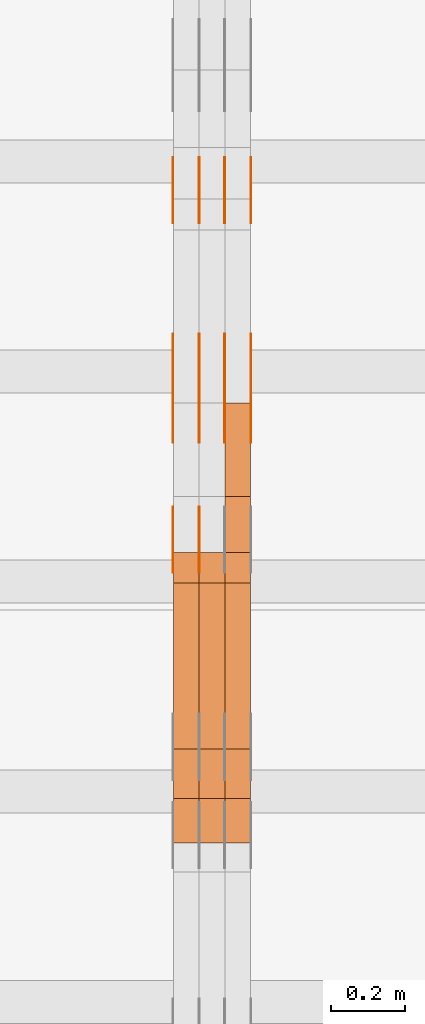
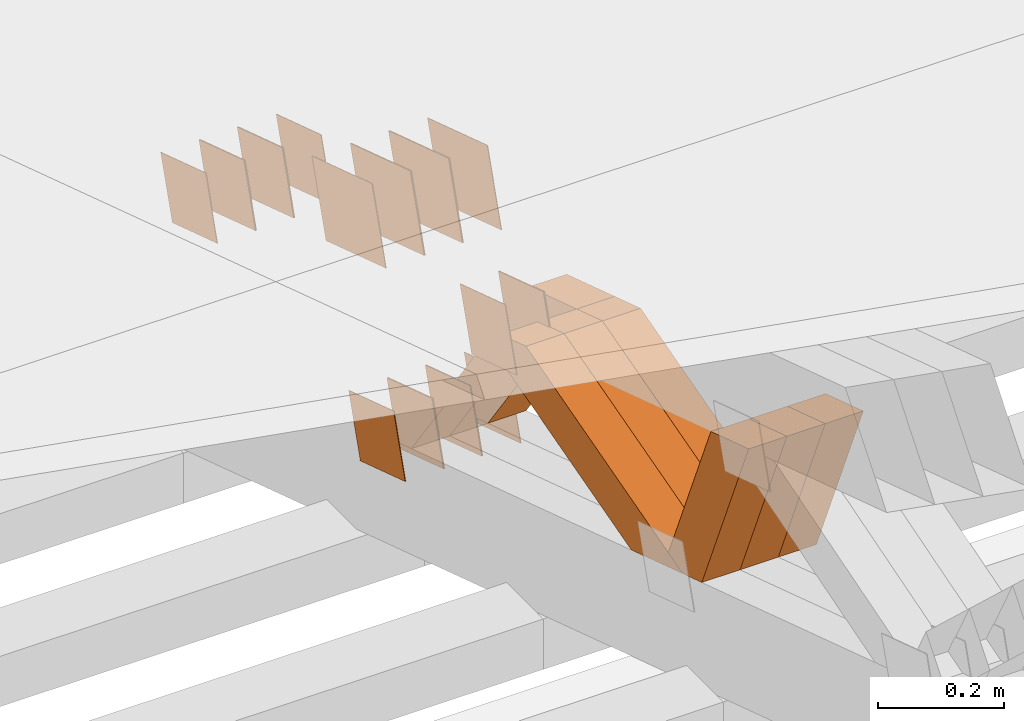
# One storey, part 206 of 385: 28 proxies.
"""IFC2X3 building model written with IfcOpenShell, lengths in millimetres."""

from ifc_helpers import new_model, entity, si_unit, converted_unit, derived_unit, direction, frame, origin, place, context, subcontext, project, spatial, polyline, outline, extrude, source, transform, mapped, material, type_object, type_shapes, element, save


model = new_model("IFC2X3")

# Units and contexts
model_context = context("Model", 3, precision=0.01, world=origin(), true_north=direction((6.12303176911189e-17, 1.0)))
body_context = subcontext(model_context, "Body", "Model", "MODEL_VIEW")
ifc_project = project(units=[si_unit("LENGTHUNIT", "METRE", prefix="MILLI"), si_unit("AREAUNIT", "SQUARE_METRE"), si_unit("VOLUMEUNIT", "CUBIC_METRE"), converted_unit("PLANEANGLEUNIT", "DEGREE", entity("IfcRatioMeasure", 0.0174532925199433), si_unit("PLANEANGLEUNIT", "RADIAN"), dimensions=[0, 0, 0, 0, 0, 0, 0]), si_unit("MASSUNIT", "GRAM", prefix="KILO"), derived_unit("MASSDENSITYUNIT", [(si_unit("MASSUNIT", "GRAM", prefix="KILO"), 1), (si_unit("LENGTHUNIT", "METRE"), -3)]), si_unit("TIMEUNIT", "SECOND"), si_unit("FREQUENCYUNIT", "HERTZ"), si_unit("THERMODYNAMICTEMPERATUREUNIT", "DEGREE_CELSIUS"), derived_unit("THERMALTRANSMITTANCEUNIT", [(si_unit("MASSUNIT", "GRAM", prefix="KILO"), 1), (si_unit("THERMODYNAMICTEMPERATUREUNIT", "KELVIN"), -1), (si_unit("TIMEUNIT", "SECOND"), -3)]), derived_unit("VOLUMETRICFLOWRATEUNIT", [(si_unit("LENGTHUNIT", "METRE"), 3), (si_unit("TIMEUNIT", "SECOND"), -1)]), si_unit("ELECTRICCURRENTUNIT", "AMPERE"), si_unit("ELECTRICVOLTAGEUNIT", "VOLT"), si_unit("POWERUNIT", "WATT"), si_unit("FORCEUNIT", "NEWTON", prefix="KILO"), si_unit("ILLUMINANCEUNIT", "LUX"), si_unit("LUMINOUSFLUXUNIT", "LUMEN"), si_unit("LUMINOUSINTENSITYUNIT", "CANDELA"), derived_unit("USERDEFINED", [(si_unit("MASSUNIT", "GRAM", prefix="KILO"), -1), (si_unit("LENGTHUNIT", "METRE"), -2), (si_unit("TIMEUNIT", "SECOND"), 3), (si_unit("LUMINOUSFLUXUNIT", "LUMEN"), 1)]), derived_unit("LINEARVELOCITYUNIT", [(si_unit("LENGTHUNIT", "METRE"), 1), (si_unit("TIMEUNIT", "SECOND"), -1)]), si_unit("PRESSUREUNIT", "PASCAL"), derived_unit("USERDEFINED", [(si_unit("LENGTHUNIT", "METRE"), -2), (si_unit("MASSUNIT", "GRAM", prefix="KILO"), 1), (si_unit("TIMEUNIT", "SECOND"), -2)])], contexts=[model_context])

# Site, building, storey
site_placement = place(None, origin())
site = spatial("IfcSite", under=ifc_project, at=site_placement, CompositionType="ELEMENT")
building_placement = place(site_placement, origin())
building = spatial("IfcBuilding", under=site, at=building_placement, CompositionType="ELEMENT")
storey_placement = place(building_placement, origin())
storey = spatial("IfcBuildingStorey", under=building, at=storey_placement, Name="Default", CompositionType="ELEMENT", Elevation=0.0)

# Proxies
ifc_material_1 = material(Name="IfcSurfaceStyle #195289")
building_element_proxy_type_1 = type_object("IfcBuildingElementProxyType", PredefinedType="NOTDEFINED", material=ifc_material_1)
shared_shape_1 = source(origin(), body_context, "Body", "SweptSolid", [
    extrude(outline(polyline([(-74.9999766548731, -60.0000019113547), (75.000223715922, -60.0000019113547), (74.9997444633404, 60.0000019113548), (-74.9999915243893, 60.0000019113547), (-74.9999766548731, -60.0000019113547)])), frame((75.0002237159219, 60.0000770809529, 0.0), z_axis=(0.0, 0.0, 1.0), x_axis=(-1.0, 0.0, 0.0)), (0.0, 0.0, 1.0), 1.29999999999999),
])
type_shapes(building_element_proxy_type_1, [shared_shape_1])
proxy_1_placement = place(building_placement, frame((15245.0, 23985.88473314, 1148.76266928562), z_axis=(-1.0, 0.0, 0.0), x_axis=(0.0, -0.951056516295154, 0.309016994374948)))
element("IfcBuildingElementProxy", 1, at=proxy_1_placement, inside=storey, type_object=building_element_proxy_type_1, material=ifc_material_1, context=body_context, shape_type="MappedRepresentation", body=[
    mapped(shared_shape_1, transform((0.0, 0.0, 0.0), scale=1.0)),
])
ifc_material_2 = material(Name="IfcSurfaceStyle #195232")
building_element_proxy_type_2 = type_object("IfcBuildingElementProxyType", PredefinedType="NOTDEFINED", material=ifc_material_2)
shared_shape_2 = source(origin(), body_context, "Body", "SweptSolid", [
    extrude(outline(polyline([(-74.9999766548731, -60.0000019113547), (75.000223715922, -60.0000019113547), (74.9997444633404, 60.0000019113548), (-74.9999915243893, 60.0000019113547), (-74.9999766548731, -60.0000019113547)])), frame((75.0002237159219, 60.0000770809529, 0.0), z_axis=(0.0, 0.0, 1.0), x_axis=(-1.0, 0.0, 0.0)), (0.0, 0.0, 1.0), 1.29999999999999),
])
type_shapes(building_element_proxy_type_2, [shared_shape_2])
proxy_2_placement = place(building_placement, frame((15246.3, 23985.88473314, 1148.76266928562), z_axis=(-1.0, 0.0, 0.0), x_axis=(0.0, -0.951056516295154, 0.309016994374948)))
element("IfcBuildingElementProxy", 2, at=proxy_2_placement, inside=storey, type_object=building_element_proxy_type_2, material=ifc_material_2, context=body_context, shape_type="MappedRepresentation", body=[
    mapped(shared_shape_2, transform((0.0, 0.0, 0.0), scale=1.0)),
])
ifc_material_3 = material(Name="IfcSurfaceStyle #195175")
building_element_proxy_type_3 = type_object("IfcBuildingElementProxyType", PredefinedType="NOTDEFINED", material=ifc_material_3)
shared_shape_3 = source(origin(), body_context, "Body", "SweptSolid", [
    extrude(outline(polyline([(-74.9999766548731, -60.0000019113547), (75.000223715922, -60.0000019113547), (74.9997444633404, 60.0000019113548), (-74.9999915243893, 60.0000019113547), (-74.9999766548731, -60.0000019113547)])), frame((75.0002237159219, 60.0000770809529, 0.0), z_axis=(0.0, 0.0, 1.0), x_axis=(-1.0, 0.0, 0.0)), (0.0, 0.0, 1.0), 1.29999999999999),
])
type_shapes(building_element_proxy_type_3, [shared_shape_3])
proxy_3_placement = place(building_placement, frame((15175.0, 23985.88473314, 1148.76266928562), z_axis=(-1.0, 0.0, 0.0), x_axis=(0.0, -0.951056516295154, 0.309016994374948)))
element("IfcBuildingElementProxy", 3, at=proxy_3_placement, inside=storey, type_object=building_element_proxy_type_3, material=ifc_material_3, context=body_context, shape_type="MappedRepresentation", body=[
    mapped(shared_shape_3, transform((0.0, 0.0, 0.0), scale=1.0)),
])
ifc_material_4 = material(Name="IfcSurfaceStyle #195118")
building_element_proxy_type_4 = type_object("IfcBuildingElementProxyType", PredefinedType="NOTDEFINED", material=ifc_material_4)
shared_shape_4 = source(origin(), body_context, "Body", "SweptSolid", [
    extrude(outline(polyline([(-74.9998841352385, -59.9999554917014), (74.9998707133932, -59.9999554917014), (74.999874704788, 59.9999554917014), (-74.9998612829427, 59.9999554917014), (-74.9998841352385, -59.9999554917014)])), frame((75.0000802775471, 60.0000306612849, 0.0), z_axis=(0.0, 0.0, 1.0), x_axis=(-1.0, 0.0, 0.0)), (0.0, 0.0, 1.0), 1.3),
])
type_shapes(building_element_proxy_type_4, [shared_shape_4])
proxy_4_placement = place(building_placement, frame((15386.3, 24338.8869142613, 728.405515087805), z_axis=(-1.0, 0.0, 0.0), x_axis=(0.0, -0.951056516295124, 0.309016994375039)))
element("IfcBuildingElementProxy", 4, at=proxy_4_placement, inside=storey, type_object=building_element_proxy_type_4, material=ifc_material_4, context=body_context, shape_type="MappedRepresentation", body=[
    mapped(shared_shape_4, transform((0.0, 0.0, 0.0), scale=1.0)),
])
ifc_material_5 = material(Name="IfcSurfaceStyle #195061")
building_element_proxy_type_5 = type_object("IfcBuildingElementProxyType", PredefinedType="NOTDEFINED", material=ifc_material_5)
shared_shape_5 = source(origin(), body_context, "Body", "SweptSolid", [
    extrude(outline(polyline([(-74.9998841352385, -59.9999554917014), (74.9998707133932, -59.9999554917014), (74.999874704788, 59.9999554917014), (-74.9998612829427, 59.9999554917014), (-74.9998841352385, -59.9999554917014)])), frame((75.0000802775471, 60.0000306612849, 0.0), z_axis=(0.0, 0.0, 1.0), x_axis=(-1.0, 0.0, 0.0)), (0.0, 0.0, 1.0), 1.3),
])
type_shapes(building_element_proxy_type_5, [shared_shape_5])
proxy_5_placement = place(building_placement, frame((15315.0, 24338.8869142613, 728.405515087805), z_axis=(-1.0, 0.0, 0.0), x_axis=(0.0, -0.951056516295124, 0.309016994375039)))
element("IfcBuildingElementProxy", 5, at=proxy_5_placement, inside=storey, type_object=building_element_proxy_type_5, material=ifc_material_5, context=body_context, shape_type="MappedRepresentation", body=[
    mapped(shared_shape_5, transform((0.0, 0.0, 0.0), scale=1.0)),
])
ifc_material_6 = material(Name="IfcSurfaceStyle #195004")
building_element_proxy_type_6 = type_object("IfcBuildingElementProxyType", PredefinedType="NOTDEFINED", material=ifc_material_6)
shared_shape_6 = source(origin(), body_context, "Body", "SweptSolid", [
    extrude(outline(polyline([(-74.9998841352385, -59.9999554917014), (74.9998707133932, -59.9999554917014), (74.999874704788, 59.9999554917014), (-74.9998612829427, 59.9999554917014), (-74.9998841352385, -59.9999554917014)])), frame((75.0000802775471, 60.0000306612849, 0.0), z_axis=(0.0, 0.0, 1.0), x_axis=(-1.0, 0.0, 0.0)), (0.0, 0.0, 1.0), 1.3),
])
type_shapes(building_element_proxy_type_6, [shared_shape_6])
proxy_6_placement = place(building_placement, frame((15316.3, 24338.8869142613, 728.405515087805), z_axis=(-1.0, 0.0, 0.0), x_axis=(0.0, -0.951056516295124, 0.309016994375039)))
element("IfcBuildingElementProxy", 6, at=proxy_6_placement, inside=storey, type_object=building_element_proxy_type_6, material=ifc_material_6, context=body_context, shape_type="MappedRepresentation", body=[
    mapped(shared_shape_6, transform((0.0, 0.0, 0.0), scale=1.0)),
])
ifc_material_7 = material(Name="IfcSurfaceStyle #194947")
building_element_proxy_type_7 = type_object("IfcBuildingElementProxyType", PredefinedType="NOTDEFINED", material=ifc_material_7)
shared_shape_7 = source(origin(), body_context, "Body", "SweptSolid", [
    extrude(outline(polyline([(-74.9998841352385, -59.9999554917014), (74.9998707133932, -59.9999554917014), (74.999874704788, 59.9999554917014), (-74.9998612829427, 59.9999554917014), (-74.9998841352385, -59.9999554917014)])), frame((75.0000802775471, 60.0000306612849, 0.0), z_axis=(0.0, 0.0, 1.0), x_axis=(-1.0, 0.0, 0.0)), (0.0, 0.0, 1.0), 1.29999999999999),
])
type_shapes(building_element_proxy_type_7, [shared_shape_7])
proxy_7_placement = place(building_placement, frame((15245.0, 24338.8869142613, 728.405515087805), z_axis=(-1.0, 0.0, 0.0), x_axis=(0.0, -0.951056516295124, 0.309016994375039)))
element("IfcBuildingElementProxy", 7, at=proxy_7_placement, inside=storey, type_object=building_element_proxy_type_7, material=ifc_material_7, context=body_context, shape_type="MappedRepresentation", body=[
    mapped(shared_shape_7, transform((0.0, 0.0, 0.0), scale=1.0)),
])
ifc_material_8 = material(Name="IfcSurfaceStyle #194890")
building_element_proxy_type_8 = type_object("IfcBuildingElementProxyType", PredefinedType="NOTDEFINED", material=ifc_material_8)
shared_shape_8 = source(origin(), body_context, "Body", "SweptSolid", [
    extrude(outline(polyline([(-74.9998841352385, -59.9999554917014), (74.9998707133932, -59.9999554917014), (74.999874704788, 59.9999554917014), (-74.9998612829427, 59.9999554917014), (-74.9998841352385, -59.9999554917014)])), frame((75.0000802775471, 60.0000306612849, 0.0), z_axis=(0.0, 0.0, 1.0), x_axis=(-1.0, 0.0, 0.0)), (0.0, 0.0, 1.0), 1.29999999999999),
])
type_shapes(building_element_proxy_type_8, [shared_shape_8])
proxy_8_placement = place(building_placement, frame((15246.3, 24338.8869142613, 728.405515087805), z_axis=(-1.0, 0.0, 0.0), x_axis=(0.0, -0.951056516295124, 0.309016994375039)))
element("IfcBuildingElementProxy", 8, at=proxy_8_placement, inside=storey, type_object=building_element_proxy_type_8, material=ifc_material_8, context=body_context, shape_type="MappedRepresentation", body=[
    mapped(shared_shape_8, transform((0.0, 0.0, 0.0), scale=1.0)),
])
ifc_material_9 = material(Name="IfcSurfaceStyle #194833")
building_element_proxy_type_9 = type_object("IfcBuildingElementProxyType", PredefinedType="NOTDEFINED", material=ifc_material_9)
shared_shape_9 = source(origin(), body_context, "Body", "SweptSolid", [
    extrude(outline(polyline([(-74.9998841352385, -59.9999554917014), (74.9998707133932, -59.9999554917014), (74.999874704788, 59.9999554917014), (-74.9998612829427, 59.9999554917014), (-74.9998841352385, -59.9999554917014)])), frame((75.0000802775471, 60.0000306612849, 0.0), z_axis=(0.0, 0.0, 1.0), x_axis=(-1.0, 0.0, 0.0)), (0.0, 0.0, 1.0), 1.29999999999999),
])
type_shapes(building_element_proxy_type_9, [shared_shape_9])
proxy_9_placement = place(building_placement, frame((15175.0, 24338.8869142613, 728.405515087805), z_axis=(-1.0, 0.0, 0.0), x_axis=(0.0, -0.951056516295124, 0.309016994375039)))
element("IfcBuildingElementProxy", 9, at=proxy_9_placement, inside=storey, type_object=building_element_proxy_type_9, material=ifc_material_9, context=body_context, shape_type="MappedRepresentation", body=[
    mapped(shared_shape_9, transform((0.0, 0.0, 0.0), scale=1.0)),
])
ifc_material_10 = material(Name="IfcSurfaceStyle #194434")
building_element_proxy_type_10 = type_object("IfcBuildingElementProxyType", PredefinedType="NOTDEFINED", material=ifc_material_10)
shared_shape_10 = source(origin(), body_context, "Body", "SweptSolid", [
    extrude(outline(polyline([(-75.0001163267648, -60.0000309352964), (75.0001029049313, -60.0000309352964), (75.0001068963143, 60.0000309352964), (-75.0000934744807, 60.0000309352964), (-75.0001163267648, -60.0000309352964)])), frame((75.0001143227305, 60.0000309352964, 0.0), z_axis=(0.0, 0.0, 1.0), x_axis=(-1.0, 0.0, 0.0)), (0.0, 0.0, 1.0), 1.3),
])
type_shapes(building_element_proxy_type_10, [shared_shape_10])
proxy_10_placement = place(building_placement, frame((15386.3, 24935.0160969462, 827.753587802763), z_axis=(-1.0, 0.0, 0.0), x_axis=(0.0, -0.951056516295154, 0.309016994374948)))
element("IfcBuildingElementProxy", 10, at=proxy_10_placement, inside=storey, type_object=building_element_proxy_type_10, material=ifc_material_10, context=body_context, shape_type="MappedRepresentation", body=[
    mapped(shared_shape_10, transform((0.0, 0.0, 0.0), scale=1.0)),
])
ifc_material_11 = material(Name="IfcSurfaceStyle #194377")
building_element_proxy_type_11 = type_object("IfcBuildingElementProxyType", PredefinedType="NOTDEFINED", material=ifc_material_11)
shared_shape_11 = source(origin(), body_context, "Body", "SweptSolid", [
    extrude(outline(polyline([(-75.0001163267648, -60.0000309352964), (75.0001029049313, -60.0000309352964), (75.0001068963143, 60.0000309352964), (-75.0000934744807, 60.0000309352964), (-75.0001163267648, -60.0000309352964)])), frame((75.0001143227305, 60.0000309352964, 0.0), z_axis=(0.0, 0.0, 1.0), x_axis=(-1.0, 0.0, 0.0)), (0.0, 0.0, 1.0), 1.3),
])
type_shapes(building_element_proxy_type_11, [shared_shape_11])
proxy_11_placement = place(building_placement, frame((15315.0, 24935.0160969462, 827.753587802763), z_axis=(-1.0, 0.0, 0.0), x_axis=(0.0, -0.951056516295154, 0.309016994374948)))
element("IfcBuildingElementProxy", 11, at=proxy_11_placement, inside=storey, type_object=building_element_proxy_type_11, material=ifc_material_11, context=body_context, shape_type="MappedRepresentation", body=[
    mapped(shared_shape_11, transform((0.0, 0.0, 0.0), scale=1.0)),
])
ifc_material_12 = material(Name="IfcSurfaceStyle #194320")
building_element_proxy_type_12 = type_object("IfcBuildingElementProxyType", PredefinedType="NOTDEFINED", material=ifc_material_12)
shared_shape_12 = source(origin(), body_context, "Body", "SweptSolid", [
    extrude(outline(polyline([(-75.0001163267648, -60.0000309352964), (75.0001029049313, -60.0000309352964), (75.0001068963143, 60.0000309352964), (-75.0000934744807, 60.0000309352964), (-75.0001163267648, -60.0000309352964)])), frame((75.0001143227305, 60.0000309352964, 0.0), z_axis=(0.0, 0.0, 1.0), x_axis=(-1.0, 0.0, 0.0)), (0.0, 0.0, 1.0), 1.3),
])
type_shapes(building_element_proxy_type_12, [shared_shape_12])
proxy_12_placement = place(building_placement, frame((15316.3, 24935.0160969462, 827.753587802763), z_axis=(-1.0, 0.0, 0.0), x_axis=(0.0, -0.951056516295154, 0.309016994374948)))
element("IfcBuildingElementProxy", 12, at=proxy_12_placement, inside=storey, type_object=building_element_proxy_type_12, material=ifc_material_12, context=body_context, shape_type="MappedRepresentation", body=[
    mapped(shared_shape_12, transform((0.0, 0.0, 0.0), scale=1.0)),
])
ifc_material_13 = material(Name="IfcSurfaceStyle #194263")
building_element_proxy_type_13 = type_object("IfcBuildingElementProxyType", PredefinedType="NOTDEFINED", material=ifc_material_13)
shared_shape_13 = source(origin(), body_context, "Body", "SweptSolid", [
    extrude(outline(polyline([(-75.0001163267648, -60.0000309352964), (75.0001029049313, -60.0000309352964), (75.0001068963143, 60.0000309352964), (-75.0000934744807, 60.0000309352964), (-75.0001163267648, -60.0000309352964)])), frame((75.0001143227305, 60.0000309352964, 0.0), z_axis=(0.0, 0.0, 1.0), x_axis=(-1.0, 0.0, 0.0)), (0.0, 0.0, 1.0), 1.29999999999999),
])
type_shapes(building_element_proxy_type_13, [shared_shape_13])
proxy_13_placement = place(building_placement, frame((15245.0, 24935.0160969462, 827.753587802763), z_axis=(-1.0, 0.0, 0.0), x_axis=(0.0, -0.951056516295154, 0.309016994374948)))
element("IfcBuildingElementProxy", 13, at=proxy_13_placement, inside=storey, type_object=building_element_proxy_type_13, material=ifc_material_13, context=body_context, shape_type="MappedRepresentation", body=[
    mapped(shared_shape_13, transform((0.0, 0.0, 0.0), scale=1.0)),
])
ifc_material_14 = material(Name="IfcSurfaceStyle #194206")
building_element_proxy_type_14 = type_object("IfcBuildingElementProxyType", PredefinedType="NOTDEFINED", material=ifc_material_14)
shared_shape_14 = source(origin(), body_context, "Body", "SweptSolid", [
    extrude(outline(polyline([(-75.0001163267648, -60.0000309352964), (75.0001029049313, -60.0000309352964), (75.0001068963143, 60.0000309352964), (-75.0000934744807, 60.0000309352964), (-75.0001163267648, -60.0000309352964)])), frame((75.0001143227305, 60.0000309352964, 0.0), z_axis=(0.0, 0.0, 1.0), x_axis=(-1.0, 0.0, 0.0)), (0.0, 0.0, 1.0), 1.29999999999999),
])
type_shapes(building_element_proxy_type_14, [shared_shape_14])
proxy_14_placement = place(building_placement, frame((15246.3, 24935.0160969462, 827.753587802763), z_axis=(-1.0, 0.0, 0.0), x_axis=(0.0, -0.951056516295154, 0.309016994374948)))
element("IfcBuildingElementProxy", 14, at=proxy_14_placement, inside=storey, type_object=building_element_proxy_type_14, material=ifc_material_14, context=body_context, shape_type="MappedRepresentation", body=[
    mapped(shared_shape_14, transform((0.0, 0.0, 0.0), scale=1.0)),
])
ifc_material_15 = material(Name="IfcSurfaceStyle #194149")
building_element_proxy_type_15 = type_object("IfcBuildingElementProxyType", PredefinedType="NOTDEFINED", material=ifc_material_15)
shared_shape_15 = source(origin(), body_context, "Body", "SweptSolid", [
    extrude(outline(polyline([(-75.0001163267648, -60.0000309352964), (75.0001029049313, -60.0000309352964), (75.0001068963143, 60.0000309352964), (-75.0000934744807, 60.0000309352964), (-75.0001163267648, -60.0000309352964)])), frame((75.0001143227305, 60.0000309352964, 0.0), z_axis=(0.0, 0.0, 1.0), x_axis=(-1.0, 0.0, 0.0)), (0.0, 0.0, 1.0), 1.29999999999999),
])
type_shapes(building_element_proxy_type_15, [shared_shape_15])
proxy_15_placement = place(building_placement, frame((15175.0, 24935.0160969462, 827.753587802763), z_axis=(-1.0, 0.0, 0.0), x_axis=(0.0, -0.951056516295154, 0.309016994374948)))
element("IfcBuildingElementProxy", 15, at=proxy_15_placement, inside=storey, type_object=building_element_proxy_type_15, material=ifc_material_15, context=body_context, shape_type="MappedRepresentation", body=[
    mapped(shared_shape_15, transform((0.0, 0.0, 0.0), scale=1.0)),
])
ifc_material_16 = material(Name="IfcSurfaceStyle #192040")
building_element_proxy_type_16 = type_object("IfcBuildingElementProxyType", PredefinedType="NOTDEFINED", material=ifc_material_16)
shared_shape_16 = source(origin(), body_context, "Body", "SweptSolid", [
    extrude(outline(polyline([(-100.000009625089, -72.0000630699202), (100.000090167682, -72.0000630699202), (100.000009625089, 72.0000630699202), (-100.000090167682, 72.0000630699202), (-100.000009625089, -72.0000630699202)])), frame((100.000090167682, 72.0000630699202, 0.0), z_axis=(0.0, 0.0, 1.0), x_axis=(-1.0, 0.0, 0.0)), (0.0, 0.0, 1.0), 1.3),
])
type_shapes(building_element_proxy_type_16, [shared_shape_16])
proxy_16_placement = place(building_placement, frame((15386.3, 24447.7695802369, 1088.58717039832), z_axis=(-1.0, 0.0, 0.0), x_axis=(0.0, -0.951056516295154, 0.309016994374948)))
element("IfcBuildingElementProxy", 16, at=proxy_16_placement, inside=storey, type_object=building_element_proxy_type_16, material=ifc_material_16, context=body_context, shape_type="MappedRepresentation", body=[
    mapped(shared_shape_16, transform((0.0, 0.0, 0.0), scale=1.0)),
])
ifc_material_17 = material(Name="IfcSurfaceStyle #191983")
building_element_proxy_type_17 = type_object("IfcBuildingElementProxyType", PredefinedType="NOTDEFINED", material=ifc_material_17)
shared_shape_17 = source(origin(), body_context, "Body", "SweptSolid", [
    extrude(outline(polyline([(-100.000009625089, -72.0000630699202), (100.000090167682, -72.0000630699202), (100.000009625089, 72.0000630699202), (-100.000090167682, 72.0000630699202), (-100.000009625089, -72.0000630699202)])), frame((100.000090167682, 72.0000630699202, 0.0), z_axis=(0.0, 0.0, 1.0), x_axis=(-1.0, 0.0, 0.0)), (0.0, 0.0, 1.0), 1.3),
])
type_shapes(building_element_proxy_type_17, [shared_shape_17])
proxy_17_placement = place(building_placement, frame((15315.0, 24447.7695802369, 1088.58717039832), z_axis=(-1.0, 0.0, 0.0), x_axis=(0.0, -0.951056516295154, 0.309016994374948)))
element("IfcBuildingElementProxy", 17, at=proxy_17_placement, inside=storey, type_object=building_element_proxy_type_17, material=ifc_material_17, context=body_context, shape_type="MappedRepresentation", body=[
    mapped(shared_shape_17, transform((0.0, 0.0, 0.0), scale=1.0)),
])
ifc_material_18 = material(Name="IfcSurfaceStyle #191926")
building_element_proxy_type_18 = type_object("IfcBuildingElementProxyType", PredefinedType="NOTDEFINED", material=ifc_material_18)
shared_shape_18 = source(origin(), body_context, "Body", "SweptSolid", [
    extrude(outline(polyline([(-100.000009625089, -72.0000630699202), (100.000090167682, -72.0000630699202), (100.000009625089, 72.0000630699202), (-100.000090167682, 72.0000630699202), (-100.000009625089, -72.0000630699202)])), frame((100.000090167682, 72.0000630699202, 0.0), z_axis=(0.0, 0.0, 1.0), x_axis=(-1.0, 0.0, 0.0)), (0.0, 0.0, 1.0), 1.3),
])
type_shapes(building_element_proxy_type_18, [shared_shape_18])
proxy_18_placement = place(building_placement, frame((15316.3, 24447.7695802369, 1088.58717039832), z_axis=(-1.0, 0.0, 0.0), x_axis=(0.0, -0.951056516295154, 0.309016994374948)))
element("IfcBuildingElementProxy", 18, at=proxy_18_placement, inside=storey, type_object=building_element_proxy_type_18, material=ifc_material_18, context=body_context, shape_type="MappedRepresentation", body=[
    mapped(shared_shape_18, transform((0.0, 0.0, 0.0), scale=1.0)),
])
ifc_material_19 = material(Name="IfcSurfaceStyle #191869")
building_element_proxy_type_19 = type_object("IfcBuildingElementProxyType", PredefinedType="NOTDEFINED", material=ifc_material_19)
shared_shape_19 = source(origin(), body_context, "Body", "SweptSolid", [
    extrude(outline(polyline([(-100.000009625089, -72.0000630699202), (100.000090167682, -72.0000630699202), (100.000009625089, 72.0000630699202), (-100.000090167682, 72.0000630699202), (-100.000009625089, -72.0000630699202)])), frame((100.000090167682, 72.0000630699202, 0.0), z_axis=(0.0, 0.0, 1.0), x_axis=(-1.0, 0.0, 0.0)), (0.0, 0.0, 1.0), 1.29999999999998),
])
type_shapes(building_element_proxy_type_19, [shared_shape_19])
proxy_19_placement = place(building_placement, frame((15245.0, 24447.7695802369, 1088.58717039832), z_axis=(-1.0, 0.0, 0.0), x_axis=(0.0, -0.951056516295154, 0.309016994374948)))
element("IfcBuildingElementProxy", 19, at=proxy_19_placement, inside=storey, type_object=building_element_proxy_type_19, material=ifc_material_19, context=body_context, shape_type="MappedRepresentation", body=[
    mapped(shared_shape_19, transform((0.0, 0.0, 0.0), scale=1.0)),
])
ifc_material_20 = material(Name="IfcSurfaceStyle #191812")
building_element_proxy_type_20 = type_object("IfcBuildingElementProxyType", PredefinedType="NOTDEFINED", material=ifc_material_20)
shared_shape_20 = source(origin(), body_context, "Body", "SweptSolid", [
    extrude(outline(polyline([(-100.000009625089, -72.0000630699202), (100.000090167682, -72.0000630699202), (100.000009625089, 72.0000630699202), (-100.000090167682, 72.0000630699202), (-100.000009625089, -72.0000630699202)])), frame((100.000090167682, 72.0000630699202, 0.0), z_axis=(0.0, 0.0, 1.0), x_axis=(-1.0, 0.0, 0.0)), (0.0, 0.0, 1.0), 1.29999999999998),
])
type_shapes(building_element_proxy_type_20, [shared_shape_20])
proxy_20_placement = place(building_placement, frame((15246.3, 24447.7695802369, 1088.58717039832), z_axis=(-1.0, 0.0, 0.0), x_axis=(0.0, -0.951056516295154, 0.309016994374948)))
element("IfcBuildingElementProxy", 20, at=proxy_20_placement, inside=storey, type_object=building_element_proxy_type_20, material=ifc_material_20, context=body_context, shape_type="MappedRepresentation", body=[
    mapped(shared_shape_20, transform((0.0, 0.0, 0.0), scale=1.0)),
])
ifc_material_21 = material(Name="IfcSurfaceStyle #191755")
building_element_proxy_type_21 = type_object("IfcBuildingElementProxyType", PredefinedType="NOTDEFINED", material=ifc_material_21)
shared_shape_21 = source(origin(), body_context, "Body", "SweptSolid", [
    extrude(outline(polyline([(-100.000009625089, -72.0000630699202), (100.000090167682, -72.0000630699202), (100.000009625089, 72.0000630699202), (-100.000090167682, 72.0000630699202), (-100.000009625089, -72.0000630699202)])), frame((100.000090167682, 72.0000630699202, 0.0), z_axis=(0.0, 0.0, 1.0), x_axis=(-1.0, 0.0, 0.0)), (0.0, 0.0, 1.0), 1.29999999999999),
])
type_shapes(building_element_proxy_type_21, [shared_shape_21])
proxy_21_placement = place(building_placement, frame((15175.0, 24447.7695802369, 1088.58717039832), z_axis=(-1.0, 0.0, 0.0), x_axis=(0.0, -0.951056516295154, 0.309016994374948)))
element("IfcBuildingElementProxy", 21, at=proxy_21_placement, inside=storey, type_object=building_element_proxy_type_21, material=ifc_material_21, context=body_context, shape_type="MappedRepresentation", body=[
    mapped(shared_shape_21, transform((0.0, 0.0, 0.0), scale=1.0)),
])
ifc_material_22 = material(Name="IfcSurfaceStyle #183634")
building_element_proxy_type_22 = type_object("IfcBuildingElementProxyType", Name="T1-W48 183632", PredefinedType="NOTDEFINED", material=ifc_material_22)
shared_shape_22 = source(origin(), body_context, "Body", "SweptSolid", [
    extrude(outline(polyline([(-179.014659681673, -47.5001725722734), (164.970934255612, -47.5001725722734), (158.689466064455, -0.000154807462590734), (117.249257288395, 47.5002499760047), (-261.894997926789, 47.5002499760047), (-179.014659681673, -47.5001725722734)])), frame((164.970934255612, 47.5002499760047, 0.0), z_axis=(0.0, 0.0, 1.0), x_axis=(-1.0, 0.0, 0.0)), (0.0, 0.0, 1.0), 70.0),
])
type_shapes(building_element_proxy_type_22, [shared_shape_22])
proxy_22_placement = place(building_placement, frame((15385.0, 23276.999081075, 1103.96808602322), z_axis=(-1.0, 0.0, 0.0), x_axis=(0.0, -0.392372359952232, 0.919806463961586)))
element("IfcBuildingElementProxy", 22, at=proxy_22_placement, inside=storey, type_object=building_element_proxy_type_22, material=ifc_material_22, Name="T1-W48", context=body_context, shape_type="MappedRepresentation", body=[
    mapped(shared_shape_22, transform((0.0, 0.0, 0.0), scale=1.0)),
])
ifc_material_23 = material(Name="IfcSurfaceStyle #183568")
building_element_proxy_type_23 = type_object("IfcBuildingElementProxyType", Name="T1-W48 183566", PredefinedType="NOTDEFINED", material=ifc_material_23)
shared_shape_23 = source(origin(), body_context, "Body", "SweptSolid", [
    extrude(outline(polyline([(-179.014659681673, -47.5001725722734), (164.970934255612, -47.5001725722734), (158.689466064455, -0.000154807462590734), (117.249257288395, 47.5002499760047), (-261.894997926789, 47.5002499760047), (-179.014659681673, -47.5001725722734)])), frame((164.970934255612, 47.5002499760047, 0.0), z_axis=(0.0, 0.0, 1.0), x_axis=(-1.0, 0.0, 0.0)), (0.0, 0.0, 1.0), 70.0),
])
type_shapes(building_element_proxy_type_23, [shared_shape_23])
proxy_23_placement = place(building_placement, frame((15315.0, 23276.999081075, 1103.96808602322), z_axis=(-1.0, 0.0, 0.0), x_axis=(0.0, -0.392372359952232, 0.919806463961586)))
element("IfcBuildingElementProxy", 23, at=proxy_23_placement, inside=storey, type_object=building_element_proxy_type_23, material=ifc_material_23, Name="T1-W48", context=body_context, shape_type="MappedRepresentation", body=[
    mapped(shared_shape_23, transform((0.0, 0.0, 0.0), scale=1.0)),
])
ifc_material_24 = material(Name="IfcSurfaceStyle #183502")
building_element_proxy_type_24 = type_object("IfcBuildingElementProxyType", Name="T1-W48 183500", PredefinedType="NOTDEFINED", material=ifc_material_24)
shared_shape_24 = source(origin(), body_context, "Body", "SweptSolid", [
    extrude(outline(polyline([(-179.014659681673, -47.5001725722734), (164.970934255612, -47.5001725722734), (158.689466064455, -0.000154807462590734), (117.249257288395, 47.5002499760047), (-261.894997926789, 47.5002499760047), (-179.014659681673, -47.5001725722734)])), frame((164.970934255612, 47.5002499760047, 0.0), z_axis=(0.0, 0.0, 1.0), x_axis=(-1.0, 0.0, 0.0)), (0.0, 0.0, 1.0), 70.0),
])
type_shapes(building_element_proxy_type_24, [shared_shape_24])
proxy_24_placement = place(building_placement, frame((15245.0, 23276.999081075, 1103.96808602322), z_axis=(-1.0, 0.0, 0.0), x_axis=(0.0, -0.392372359952232, 0.919806463961586)))
element("IfcBuildingElementProxy", 24, at=proxy_24_placement, inside=storey, type_object=building_element_proxy_type_24, material=ifc_material_24, Name="T1-W48", context=body_context, shape_type="MappedRepresentation", body=[
    mapped(shared_shape_24, transform((0.0, 0.0, 0.0), scale=1.0)),
])
ifc_material_25 = material(Name="IfcSurfaceStyle #183238")
building_element_proxy_type_25 = type_object("IfcBuildingElementProxyType", Name="T1-W16 183236", PredefinedType="NOTDEFINED", material=ifc_material_25)
shared_shape_25 = source(origin(), body_context, "Body", "SweptSolid", [
    extrude(outline(polyline([(-370.757125176074, -47.4999438400901), (145.934648032773, -47.4999438400902), (217.511780472151, -4.11857860007858e-05), (234.91308660316, 47.4999644329832), (-227.602389932009, 47.4999644329832), (-370.757125176074, -47.4999438400901)])), frame((234.913162148205, 47.5000075544853, 0.0), z_axis=(0.0, 0.0, 1.0), x_axis=(-1.0, 0.0, 0.0)), (0.0, 0.0, 1.0), 70.0),
])
type_shapes(building_element_proxy_type_25, [shared_shape_25])
proxy_25_placement = place(building_placement, frame((15385.0, 23927.1704945031, 1199.43003244777), z_axis=(-1.0, 0.0, 0.0), x_axis=(0.0, -0.963308155550006, -0.268397834288666)))
element("IfcBuildingElementProxy", 25, at=proxy_25_placement, inside=storey, type_object=building_element_proxy_type_25, material=ifc_material_25, Name="T1-W16", context=body_context, shape_type="MappedRepresentation", body=[
    mapped(shared_shape_25, transform((0.0, 0.0, 0.0), scale=1.0)),
])
ifc_material_26 = material(Name="IfcSurfaceStyle #183172")
building_element_proxy_type_26 = type_object("IfcBuildingElementProxyType", Name="T1-W16 183170", PredefinedType="NOTDEFINED", material=ifc_material_26)
shared_shape_26 = source(origin(), body_context, "Body", "SweptSolid", [
    extrude(outline(polyline([(-370.757125176074, -47.4999438400901), (145.934648032773, -47.4999438400902), (217.511780472151, -4.11857860007858e-05), (234.91308660316, 47.4999644329832), (-227.602389932009, 47.4999644329832), (-370.757125176074, -47.4999438400901)])), frame((234.913162148205, 47.5000075544853, 0.0), z_axis=(0.0, 0.0, 1.0), x_axis=(-1.0, 0.0, 0.0)), (0.0, 0.0, 1.0), 70.0),
])
type_shapes(building_element_proxy_type_26, [shared_shape_26])
proxy_26_placement = place(building_placement, frame((15315.0, 23927.1704945031, 1199.43003244777), z_axis=(-1.0, 0.0, 0.0), x_axis=(0.0, -0.963308155550006, -0.268397834288666)))
element("IfcBuildingElementProxy", 26, at=proxy_26_placement, inside=storey, type_object=building_element_proxy_type_26, material=ifc_material_26, Name="T1-W16", context=body_context, shape_type="MappedRepresentation", body=[
    mapped(shared_shape_26, transform((0.0, 0.0, 0.0), scale=1.0)),
])
ifc_material_27 = material(Name="IfcSurfaceStyle #183106")
building_element_proxy_type_27 = type_object("IfcBuildingElementProxyType", Name="T1-W16 183104", PredefinedType="NOTDEFINED", material=ifc_material_27)
shared_shape_27 = source(origin(), body_context, "Body", "SweptSolid", [
    extrude(outline(polyline([(-370.757125176074, -47.4999438400901), (145.934648032773, -47.4999438400902), (217.511780472151, -4.11857860007858e-05), (234.91308660316, 47.4999644329832), (-227.602389932009, 47.4999644329832), (-370.757125176074, -47.4999438400901)])), frame((234.913162148205, 47.5000075544853, 0.0), z_axis=(0.0, 0.0, 1.0), x_axis=(-1.0, 0.0, 0.0)), (0.0, 0.0, 1.0), 70.0),
])
type_shapes(building_element_proxy_type_27, [shared_shape_27])
proxy_27_placement = place(building_placement, frame((15245.0, 23927.1704945031, 1199.43003244777), z_axis=(-1.0, 0.0, 0.0), x_axis=(0.0, -0.963308155550006, -0.268397834288666)))
element("IfcBuildingElementProxy", 27, at=proxy_27_placement, inside=storey, type_object=building_element_proxy_type_27, material=ifc_material_27, Name="T1-W16", context=body_context, shape_type="MappedRepresentation", body=[
    mapped(shared_shape_27, transform((0.0, 0.0, 0.0), scale=1.0)),
])
ifc_material_28 = material(Name="IfcSurfaceStyle #182842")
building_element_proxy_type_28 = type_object("IfcBuildingElementProxyType", Name="T1-W24 182840", PredefinedType="NOTDEFINED", material=ifc_material_28)
shared_shape_28 = source(origin(), body_context, "Body", "SweptSolid", [
    extrude(outline(polyline([(-215.642157779899, -47.4998772343114), (220.829928576248, -47.4998772343114), (202.182343865616, 6.34871490324596e-05), (137.545638852774, 47.4998454907369), (-344.915753514738, 47.4998454907369), (-215.642157779899, -47.4998772343114)])), frame((220.830079609702, 47.500154567531, 0.0), z_axis=(0.0, 0.0, 1.0), x_axis=(-1.0, 0.0, 0.0)), (0.0, 0.0, 1.0), 70.0),
])
type_shapes(building_element_proxy_type_28, [shared_shape_28])
proxy_28_placement = place(building_placement, frame((15385.0, 24227.7045444998, 781.019082122604), z_axis=(-1.0, 0.0, 0.0), x_axis=(0.0, -0.583381854128324, 0.812198012970851)))
element("IfcBuildingElementProxy", 28, at=proxy_28_placement, inside=storey, type_object=building_element_proxy_type_28, material=ifc_material_28, Name="T1-W24", context=body_context, shape_type="MappedRepresentation", body=[
    mapped(shared_shape_28, transform((0.0, 0.0, 0.0), scale=1.0)),
])

save(model, "model.ifc")
